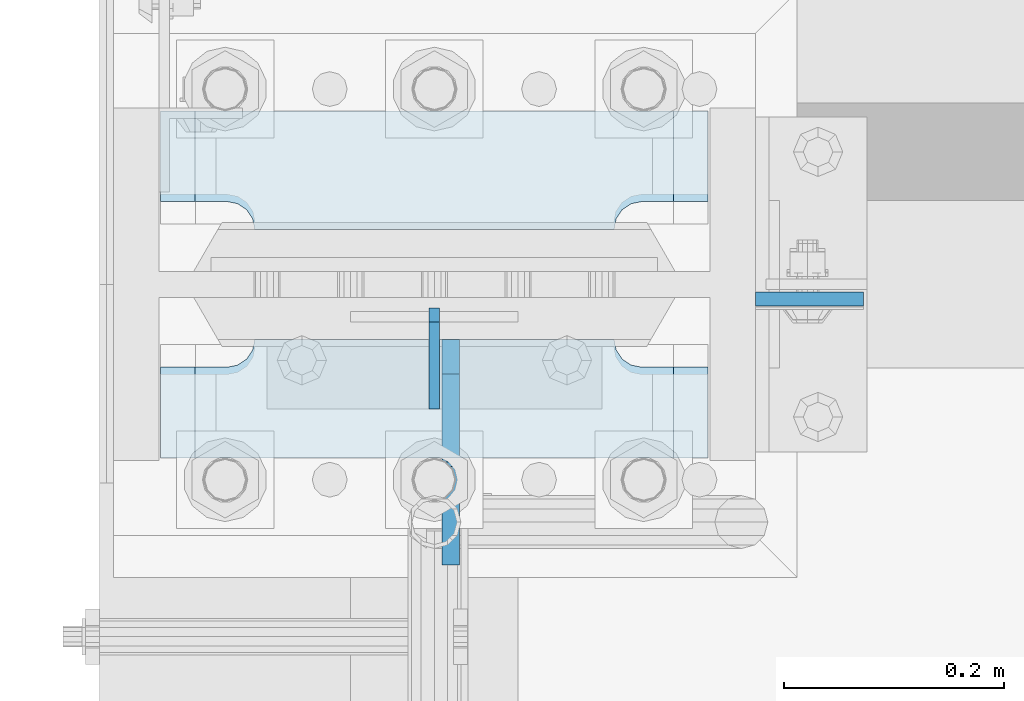
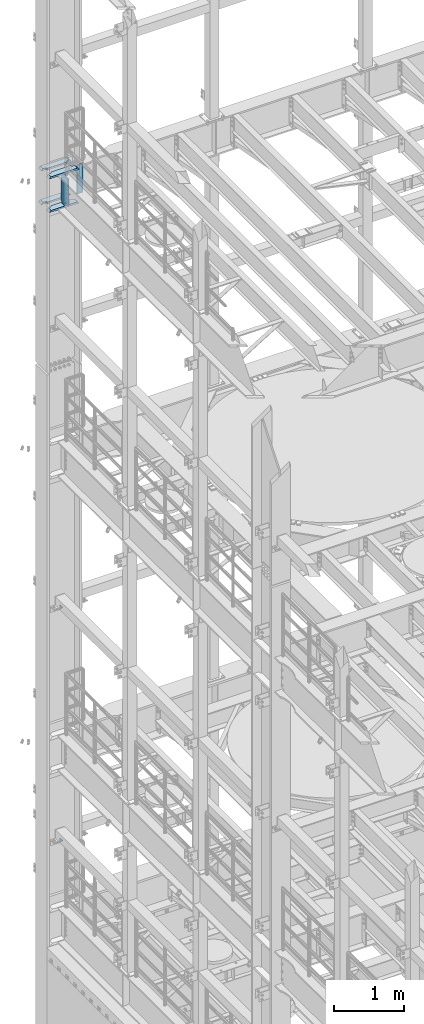
# One storey, part 1771 of 1876: 8 plates, 2 elements without a shape of their own.
"""IFC2X3 building model written with IfcOpenShell, lengths in millimetres."""

from ifc_helpers import new_model, si_unit, frame, origin_with_axes, place, context, subcontext, project, spatial, faceted_brep, material, type_object, element, aggregate, save


model = new_model("IFC2X3")

# Units and contexts
model_context = context("Model", 3, precision=1e-05, world=origin_with_axes())
body_context = subcontext(model_context, "Body", "Model", "MODEL_VIEW")
ifc_project = project(units=[si_unit("LENGTHUNIT", "METRE", prefix="MILLI"), si_unit("AREAUNIT", "SQUARE_METRE"), si_unit("VOLUMEUNIT", "CUBIC_METRE"), si_unit("MASSUNIT", "GRAM", prefix="KILO"), si_unit("TIMEUNIT", "SECOND"), si_unit("PLANEANGLEUNIT", "RADIAN"), si_unit("SOLIDANGLEUNIT", "STERADIAN"), si_unit("THERMODYNAMICTEMPERATUREUNIT", "DEGREE_CELSIUS"), si_unit("LUMINOUSINTENSITYUNIT", "LUMEN")], contexts=[model_context])

# Site, building, storey
site_placement = place(None, origin_with_axes())
site = spatial("IfcSite", under=ifc_project, at=site_placement, CompositionType="ELEMENT")
building_placement = place(site_placement, origin_with_axes())
building = spatial("IfcBuilding", under=site, at=building_placement, Name="Undefined", CompositionType="ELEMENT")
storey_placement = place(building_placement, origin_with_axes())
storey = spatial("IfcBuildingStorey", under=building, at=storey_placement, Name="Undefined", CompositionType="ELEMENT", Elevation=0.0)

# Assembly, plates
assembly_1_placement = place(storey_placement, origin_with_axes())
assembly_1 = element("IfcElementAssembly", 1, at=assembly_1_placement, inside=storey, Name="COLUMN", AssemblyPlace="NOTDEFINED", PredefinedType="RIGID_FRAME")
ifc_material_1 = material(Name="STEEL/A36")
plate_type_1 = type_object("IfcPlateType", PredefinedType="NOTDEFINED")
plate_1_placement = place(assembly_1_placement, frame((0.0, 13602.4937494032, 10325.1), z_axis=(0.0, 0.707106781186548, 0.707106781186548), x_axis=(0.0, 0.707106781186548, -0.707106781186548)))
plate_1 = element("IfcPlate", 2, at=plate_1_placement, type_object=plate_type_1, material=ifc_material_1, Name="PLATE", context=body_context, shape_type="Brep", body=[
    faceted_brep([(0.0, -4.76249999999982, 0.0), (56.1266013136901, -4.76249999997708, 56.1266013135391), (56.1266013136883, 4.76250000002256, 56.1266013135428), (0.0, 4.76249999999982, 0.0), (74.0871132860975, -4.7624999999698, 56.1266013135246), (74.0871132860993, 4.76250000002983, 56.1266013135282), (130.213714599717, -4.76249999994707, -1.30967237055302e-10), (130.213714599715, 4.76250000005257, -1.23691279441118e-10)], [[[0, 1, 2, 3]], [[1, 4, 5, 2]], [[4, 6, 7, 5]], [[6, 0, 3, 7]], [[5, 7, 3, 2]], [[6, 4, 1, 0]]]),
])
plate_2_placement = place(assembly_1_placement, frame((0.0, 13602.4937494032, 6235.7), z_axis=(0.0, 0.707106781186548, 0.707106781186548), x_axis=(0.0, 0.707106781186548, -0.707106781186548)))
plate_2 = element("IfcPlate", 3, at=plate_2_placement, type_object=plate_type_1, material=ifc_material_1, Name="PLATE", context=body_context, shape_type="Brep", body=[
    faceted_brep([(0.0, -4.76249999999982, 0.0), (56.1266013136901, -4.76249999997708, 56.1266013135391), (56.1266013136883, 4.76250000002256, 56.1266013135428), (0.0, 4.76249999999982, 0.0), (74.0871132860975, -4.7624999999698, 56.1266013135246), (74.0871132860993, 4.76250000002983, 56.1266013135282), (130.213714599717, -4.76249999994707, -1.30967237055302e-10), (130.213714599715, 4.76250000005257, -1.23691279441118e-10)], [[[0, 1, 2, 3]], [[1, 4, 5, 2]], [[4, 6, 7, 5]], [[6, 0, 3, 7]], [[5, 7, 3, 2]], [[6, 4, 1, 0]]]),
])
aggregate(assembly_1, [plate_1, plate_2])

assembly_2_placement = place(storey_placement, origin_with_axes())
assembly_2 = element("IfcElementAssembly", 4, at=assembly_2_placement, inside=storey, Name="COLUMN", AssemblyPlace="NOTDEFINED", PredefinedType="RIGID_FRAME")
ifc_material_2 = material(Name="STEEL/A572-50")
plate_type_2 = type_object("IfcPlateType", PredefinedType="NOTDEFINED")
plate_3_placement = place(assembly_2_placement, frame((292.1, 13702.5069998741, 17929.225), z_axis=(1.0, 0.0, 0.0), x_axis=(0.0, 0.0, -1.0)))
plate_3 = element("IfcPlate", 5, at=plate_3_placement, type_object=plate_type_2, material=ifc_material_2, Name="PLATE", context=body_context, shape_type="Brep", body=[
    faceted_brep([(0.0, -6.35000000000036, 0.0), (0.0, -6.34999999999991, 98.4250030517578), (0.0, 6.34999999999991, 98.4250030517578), (0.0, 6.35000000000036, 0.0), (514.349975585938, -6.35000000000036, 98.4250030517578), (514.349975585938, 6.35000000000036, 98.4250030517578), (514.349975585938, -6.35000000000036, 0.0), (514.349975585938, 6.35000000000036, 0.0)], [[[0, 1, 2, 3]], [[1, 4, 5, 2]], [[4, 6, 7, 5]], [[6, 0, 3, 7]], [[5, 7, 3, 2]], [[6, 4, 1, 0]]]),
])
plate_type_3 = type_object("IfcPlateType", PredefinedType="NOTDEFINED")
plate_4_placement = place(assembly_2_placement, frame((-249.2375, 13766.00625, 17376.775012207), z_axis=(1.0, 0.0, 0.0), x_axis=(0.0, 1.0, 0.0)))
plate_4 = element("IfcPlate", 6, at=plate_4_placement, type_object=plate_type_3, material=ifc_material_2, Name="PLATE", context=body_context, shape_type="Brep", body=[
    faceted_brep([(107.949996948242, -15.875, 498.475006103516), (107.949996948242, 15.875, 467.025007631571), (25.3999996185303, 15.875, 467.025007631571), (25.3999996185303, -15.875, 498.475006103516), (23.4665397733534, -15.875, 428.429848211837), (25.3999996185303, -15.875, 438.150007247925), (25.3999996185303, 15.875, 438.150007247925), (23.4665397733534, 15.875, 428.429848211837), (17.9605119723965, -15.875, 420.189495275529), (17.9605119723965, 15.875, 420.189495275529), (9.72015903608917, -15.875, 414.683467474573), (9.72015903608917, 15.875, 414.683467474573), (0.0, -15.875, 412.750007629395), (0.0, 15.875, 412.750007629395), (0.0, -15.875, 85.7249984741211), (0.0, 15.875, 85.7249984741211), (9.72015903609099, -15.875, 83.7915386289454), (9.72015903609099, 15.875, 83.7915386289454), (17.9605119723983, -15.875, 78.2855108279892), (17.9605119723983, 15.875, 78.2855108279892), (23.4665397733552, -15.875, 70.0451578916817), (23.4665397733552, 15.875, 70.0451578916817), (25.3999996185303, -15.875, 60.3249988555908), (25.3999996185303, 15.875, 60.3249988555908), (25.3999996185303, 15.875, 31.449998471945), (25.3999996185303, -15.875, 0.0), (107.949996948242, 15.875, 31.449998471945), (107.949996948242, -15.875, 0.0)], [[[0, 1, 2, 3]], [[4, 5, 6, 7]], [[8, 4, 7, 9]], [[10, 8, 9, 11]], [[12, 10, 11, 13]], [[14, 12, 13, 15]], [[16, 14, 15, 17]], [[18, 16, 17, 19]], [[20, 18, 19, 21]], [[22, 20, 21, 23]], [[22, 23, 24, 25]], [[26, 27, 25, 24]], [[5, 4, 8, 10, 12, 14, 16, 18, 20, 22, 25, 27, 0, 3]], [[6, 5, 3, 2]], [[26, 24, 23, 21, 19, 17, 15, 13, 11, 9, 7, 6, 2, 1]], [[27, 26, 1, 0]]]),
])
plate_5_placement = place(assembly_2_placement, frame((-249.2375, 13766.00625, 17967.325), z_axis=(1.0, 0.0, 0.0), x_axis=(0.0, 1.0, 0.0)))
plate_5 = element("IfcPlate", 7, at=plate_5_placement, type_object=plate_type_3, material=ifc_material_2, Name="PLATE", context=body_context, shape_type="Brep", body=[
    faceted_brep([(107.949996948242, -15.875, 498.475006103516), (107.949996948242, 15.875, 467.025007631571), (25.3999996185303, 15.875, 467.025007631571), (25.3999996185303, -15.875, 498.475006103516), (23.4665397733534, -15.875, 428.429848211837), (25.3999996185303, -15.875, 438.150007247925), (25.3999996185303, 15.875, 438.150007247925), (23.4665397733534, 15.875, 428.429848211837), (17.9605119723965, -15.875, 420.189495275529), (17.9605119723965, 15.875, 420.189495275529), (9.72015903608917, -15.875, 414.683467474573), (9.72015903608917, 15.875, 414.683467474573), (0.0, -15.875, 412.750007629395), (0.0, 15.875, 412.750007629395), (0.0, -15.875, 85.7249984741211), (0.0, 15.875, 85.7249984741211), (9.72015903609099, -15.875, 83.7915386289454), (9.72015903609099, 15.875, 83.7915386289454), (17.9605119723983, -15.875, 78.2855108279892), (17.9605119723983, 15.875, 78.2855108279892), (23.4665397733552, -15.875, 70.0451578916817), (23.4665397733552, 15.875, 70.0451578916817), (25.3999996185303, -15.875, 60.3249988555908), (25.3999996185303, 15.875, 60.3249988555908), (25.3999996185303, 15.875, 31.449998471945), (25.3999996185303, -15.875, 0.0), (107.949996948242, 15.875, 31.449998471945), (107.949996948242, -15.875, 0.0)], [[[0, 1, 2, 3]], [[4, 5, 6, 7]], [[8, 4, 7, 9]], [[10, 8, 9, 11]], [[12, 10, 11, 13]], [[14, 12, 13, 15]], [[16, 14, 15, 17]], [[18, 16, 17, 19]], [[20, 18, 19, 21]], [[22, 20, 21, 23]], [[22, 23, 24, 25]], [[26, 27, 25, 24]], [[5, 4, 8, 10, 12, 14, 16, 18, 20, 22, 25, 27, 0, 3]], [[6, 5, 3, 2]], [[26, 24, 23, 21, 19, 17, 15, 13, 11, 9, 7, 6, 2, 1]], [[27, 26, 1, 0]]]),
])
plate_6_placement = place(assembly_2_placement, frame((-249.2375, 13558.04375, 17376.775012207), z_axis=(1.0, 0.0, 0.0), x_axis=(0.0, 1.0, 0.0)))
plate_6 = element("IfcPlate", 8, at=plate_6_placement, type_object=plate_type_3, material=ifc_material_2, Name="PLATE", context=body_context, shape_type="Brep", body=[
    faceted_brep([(82.5499973297119, -15.875, 498.475006103516), (82.5499973297119, 15.875, 467.025007631571), (0.0, 15.875, 467.025007631571), (0.0, -15.875, 498.475006103516), (82.5499973297119, 15.875, 31.449998471945), (82.5499973297119, -15.875, 0.0), (0.0, -15.875, 0.0), (0.0, 15.875, 31.449998471945), (82.5499973297119, 15.875, 60.3249988555908), (82.5499973297119, -15.875, 60.3249988555908), (84.4834571748879, -15.875, 70.045157891682), (84.4834571748879, 15.875, 70.045157891682), (89.9894849758439, -15.875, 78.2855108279893), (89.9894849758439, 15.875, 78.2855108279893), (98.2298379121512, -15.875, 83.7915386289454), (98.2298379121512, 15.875, 83.7915386289454), (107.949996948242, -15.875, 85.7249984741211), (107.949996948242, 15.875, 85.7249984741211), (107.949996948242, -15.875, 412.750007629395), (107.949996948242, 15.875, 412.750007629395), (98.2298379121512, -15.875, 414.68346747457), (98.2298379121512, 15.875, 414.68346747457), (89.989484975843, -15.875, 420.189495275526), (89.989484975843, 15.875, 420.189495275526), (84.483457174887, -15.875, 428.429848211834), (84.483457174887, 15.875, 428.429848211834), (82.5499973297119, -15.875, 438.150007247925), (82.5499973297119, 15.875, 438.150007247925)], [[[0, 1, 2, 3]], [[4, 5, 6, 7]], [[8, 9, 5, 4]], [[10, 9, 8, 11]], [[12, 10, 11, 13]], [[14, 12, 13, 15]], [[16, 14, 15, 17]], [[18, 16, 17, 19]], [[20, 18, 19, 21]], [[22, 20, 21, 23]], [[24, 22, 23, 25]], [[26, 24, 25, 27]], [[6, 5, 9, 10, 12, 14, 16, 18, 20, 22, 24, 26, 0, 3]], [[7, 6, 3, 2]], [[27, 25, 23, 21, 19, 17, 15, 13, 11, 8, 4, 7, 2, 1]], [[26, 27, 1, 0]]]),
])
plate_7_placement = place(assembly_2_placement, frame((-249.2375, 13558.04375, 17967.325), z_axis=(1.0, 0.0, 0.0), x_axis=(0.0, 1.0, 0.0)))
plate_7 = element("IfcPlate", 9, at=plate_7_placement, type_object=plate_type_3, material=ifc_material_2, Name="PLATE", context=body_context, shape_type="Brep", body=[
    faceted_brep([(82.5499973297119, -15.875, 498.475006103516), (82.5499973297119, 15.875, 467.025007631571), (0.0, 15.875, 467.025007631571), (0.0, -15.875, 498.475006103516), (82.5499973297119, 15.875, 31.449998471945), (82.5499973297119, -15.875, 0.0), (0.0, -15.875, 0.0), (0.0, 15.875, 31.449998471945), (82.5499973297119, 15.875, 60.3249988555908), (82.5499973297119, -15.875, 60.3249988555908), (84.4834571748879, -15.875, 70.045157891682), (84.4834571748879, 15.875, 70.045157891682), (89.9894849758439, -15.875, 78.2855108279893), (89.9894849758439, 15.875, 78.2855108279893), (98.2298379121512, -15.875, 83.7915386289454), (98.2298379121512, 15.875, 83.7915386289454), (107.949996948242, -15.875, 85.7249984741211), (107.949996948242, 15.875, 85.7249984741211), (107.949996948242, -15.875, 412.750007629395), (107.949996948242, 15.875, 412.750007629395), (98.2298379121512, -15.875, 414.68346747457), (98.2298379121512, 15.875, 414.68346747457), (89.989484975843, -15.875, 420.189495275526), (89.989484975843, 15.875, 420.189495275526), (84.483457174887, -15.875, 428.429848211834), (84.483457174887, 15.875, 428.429848211834), (82.5499973297119, -15.875, 438.150007247925), (82.5499973297119, 15.875, 438.150007247925)], [[[0, 1, 2, 3]], [[4, 5, 6, 7]], [[8, 9, 5, 4]], [[10, 9, 8, 11]], [[12, 10, 11, 13]], [[14, 12, 13, 15]], [[16, 14, 15, 17]], [[18, 16, 17, 19]], [[20, 18, 19, 21]], [[22, 20, 21, 23]], [[24, 22, 23, 25]], [[26, 24, 25, 27]], [[6, 5, 9, 10, 12, 14, 16, 18, 20, 22, 24, 26, 0, 3]], [[7, 6, 3, 2]], [[27, 25, 23, 21, 19, 17, 15, 13, 11, 8, 4, 7, 2, 1]], [[26, 27, 1, 0]]]),
])
plate_type_4 = type_object("IfcPlateType", PredefinedType="NOTDEFINED")
plate_8_placement = place(assembly_2_placement, frame((15.081249999999, 13665.99375, 17951.45), z_axis=(0.0, -1.0, 0.0), x_axis=(0.0, 0.0, -1.0)))
plate_8 = element("IfcPlate", 10, at=plate_8_placement, type_object=plate_type_4, material=ifc_material_1, Name="PLATE", context=body_context, shape_type="Brep", body=[
    faceted_brep([(488.949999999997, -7.93749999999998, 205.581253456207), (488.949999999997, -7.93749999999998, 120.649999809266), (488.949999999997, 7.93749999999999, 120.649999809266), (488.949999999997, 7.93749999999999, 205.581253051758), (489.916729922585, -7.93749999999998, 115.78992029122), (489.916729922585, 7.93749999999999, 115.78992029122), (492.669743823062, -7.93749999999998, 111.669743823067), (492.669743823062, 7.93749999999999, 111.669743823067), (496.789920291216, -7.93749999999998, 108.916729922588), (496.789920291216, 7.93749999999999, 108.916729922588), (501.649999809262, -7.93749999999998, 107.950000000001), (501.649999809262, 7.93749999999999, 107.950000000001), (558.799987792969, -7.93749999999998, 107.950000000001), (558.799987792969, 7.93749999999999, 107.950000000001), (31.7499984741225, -7.93749999999998, 205.581256103516), (31.7499984741225, 7.93749999999999, 205.581253051758), (31.7499984741225, 7.93749999999999, 120.649999809266), (31.7499984741225, -7.93749999999998, 120.649999809266), (30.783268551535, 7.93749999999999, 115.78992029122), (30.783268551535, -7.93749999999998, 115.78992029122), (28.0302546510575, 7.93749999999999, 111.669743823067), (28.0302546510575, -7.93749999999998, 111.669743823067), (23.9100781829038, 7.93749999999999, 108.916729922588), (23.9100781829038, -7.93749999999998, 108.916729922588), (19.0499986648574, 7.93749999999999, 107.950000000001), (19.0499986648574, -7.93749999999998, 107.950000000001), (0.0, 7.93749999999999, 107.950000000001), (0.0, -7.93749999999998, 107.950000000001), (0.0, 7.93749999999999, 31.75), (0.0, -7.93749999999998, 31.75), (31.75, -7.93749999999998, 0.0), (31.75, 7.93749999999999, 0.0), (527.049987792969, -7.93749999999998, 0.0), (527.049987792969, 7.93749999999999, 0.0), (558.799987792969, -7.93749999999998, 31.75), (558.799987792969, 7.93749999999999, 31.75)], [[[0, 1, 2, 3]], [[4, 5, 2, 1]], [[6, 7, 5, 4]], [[8, 9, 7, 6]], [[10, 11, 9, 8]], [[12, 13, 11, 10]], [[14, 15, 16, 17]], [[17, 16, 18, 19]], [[19, 18, 20, 21]], [[21, 20, 22, 23]], [[23, 22, 24, 25]], [[25, 24, 26, 27]], [[28, 29, 27, 26]], [[30, 29, 28, 31]], [[32, 30, 31, 33]], [[34, 32, 33, 35]], [[8, 6, 4, 1, 0, 14, 17, 19, 21, 23, 25, 27, 29, 30, 32, 34, 12, 10]], [[15, 14, 0, 3]], [[35, 33, 31, 28, 26, 24, 22, 20, 18, 16, 15, 3, 2, 5, 7, 9, 11, 13]], [[34, 35, 13, 12]]]),
])
aggregate(assembly_2, [plate_4, plate_5, plate_6, plate_7, plate_8, plate_3])

save(model, "model.ifc")
